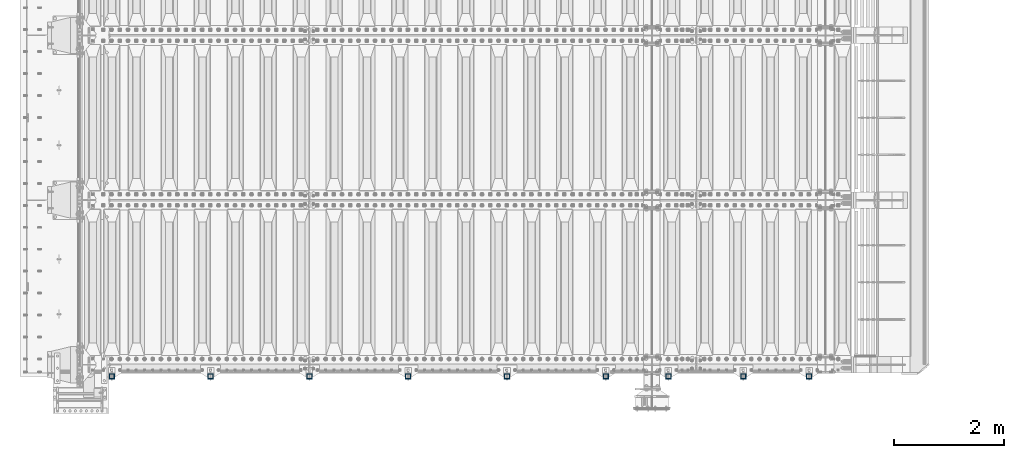
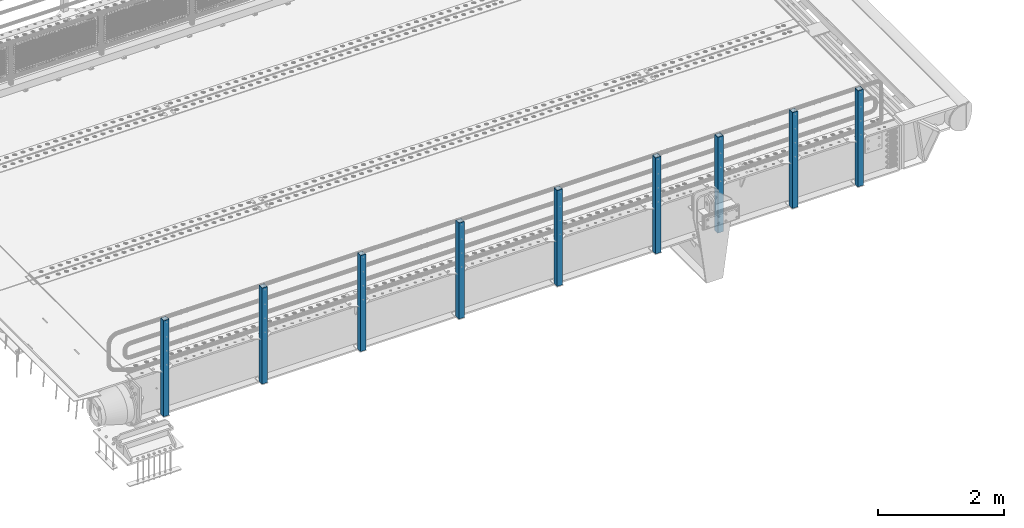
# One storey, part 59 of 219: 9 columns.
"""IFC2X3 building model written with IfcOpenShell, lengths in millimetres."""

import ifcopenshell
import ifcopenshell.guid

model = None  # the IFC model being written
_history = None  # IfcOwnerHistory: only IFC2X3 demands one
_inside = {}  # id of a spatial element -> (the spatial element, [elements in it])
_under = {}  # id of a project, library or spatial element -> (it, [spatial elements below it])
_declared = {}  # id of a project -> (the project, [libraries it declares])
_typed = {}  # id of a type object -> (the type object, [elements of that type])
_made_of = {}  # id of a material, layer set ... -> (it, [elements and type objects made of it])


def new_model(schema):
    """Start an empty IFC model of exactly this schema.

    Asked for "IFC4X3", IfcOpenShell would pick the latest addendum, in which some entities
    have other attributes; the version numbers below select the first issue.
    IFC2X3 requires an IfcOwnerHistory on every rooted entity: one is made here for all.
    """
    global model, _history
    if schema == "IFC4X3":
        model = ifcopenshell.file(schema_version=(4, 3, 0, 0))
    else:
        model = ifcopenshell.file(schema=schema)
    _inside.clear()
    _under.clear()
    _declared.clear()
    _typed.clear()
    _made_of.clear()
    _history = None
    if model.schema == "IFC2X3":
        org = make("IfcOrganization", Name="unknown")
        user = make(
            "IfcPersonAndOrganization",
            ThePerson=make("IfcPerson", FamilyName="unknown"),
            TheOrganization=org,
        )
        app = make(
            "IfcApplication",
            ApplicationDeveloper=org,
            Version="unknown",
            ApplicationFullName="unknown",
            ApplicationIdentifier="unknown",
        )
        _history = make(
            "IfcOwnerHistory",
            OwningUser=user,
            OwningApplication=app,
            ChangeAction="ADDED",
            CreationDate=0,
        )
    return model


def make(cls, **values):
    """One entity of the class cls with the attributes given. An attribute that is None is left unset."""
    return model.create_entity(
        cls, **{name: value for name, value in values.items() if value is not None}
    )


def rooted(cls, **values):
    """An entity with a GlobalId (a new one), such as an element, a storey or a relation."""
    return make(cls, GlobalId=ifcopenshell.guid.new(), OwnerHistory=_history, **values)


def si_unit(unit_type, name, prefix=None):
    """IfcSIUnit, for example si_unit("LENGTHUNIT", "METRE", prefix="MILLI")."""
    return make("IfcSIUnit", UnitType=unit_type, Prefix=prefix, Name=name)


def assignment(units):
    """IfcUnitAssignment: the units of a project."""
    return None if units is None else make("IfcUnitAssignment", Units=units)


def point(xyz):
    """IfcCartesianPoint."""
    return None if xyz is None else make("IfcCartesianPoint", Coordinates=xyz)


def direction(xyz):
    """IfcDirection."""
    return None if xyz is None else make("IfcDirection", DirectionRatios=xyz)


def frame(location, z_axis=None, x_axis=None):
    """IfcAxis2Placement3D, a coordinate frame: its origin and axes. An axis left out is left unset."""
    return make(
        "IfcAxis2Placement3D",
        Location=point(location),
        Axis=direction(z_axis),
        RefDirection=direction(x_axis),
    )


def origin_with_axes():
    """The frame at (0, 0, 0) with the z axis (0, 0, 1) and the x axis (1, 0, 0) written out."""
    return frame((0.0, 0.0, 0.0), z_axis=(0.0, 0.0, 1.0), x_axis=(1.0, 0.0, 0.0))


def place(relative_to, where):
    """IfcLocalPlacement: puts the frame where relative to a parent placement (None: the world)."""
    return make(
        "IfcLocalPlacement", PlacementRelTo=relative_to, RelativePlacement=where
    )


def context(
    kind, dimensions, precision=None, world=None, true_north=None, identifier=None
):
    """IfcGeometricRepresentationContext, for example the 3D "Model" context."""
    return make(
        "IfcGeometricRepresentationContext",
        ContextIdentifier=identifier,
        ContextType=kind,
        CoordinateSpaceDimension=dimensions,
        Precision=precision,
        WorldCoordinateSystem=world,
        TrueNorth=true_north,
    )


def subcontext(parent, identifier, kind, view, scale=None):
    """IfcGeometricRepresentationSubContext, for example "Body" below "Model"."""
    return make(
        "IfcGeometricRepresentationSubContext",
        ContextIdentifier=identifier,
        ContextType=kind,
        ParentContext=parent,
        TargetScale=scale,
        TargetView=view,
    )


def project(units=None, contexts=None):
    """IfcProject with its units and contexts."""
    return rooted(
        "IfcProject",
        Name="project",
        RepresentationContexts=contexts,
        UnitsInContext=assignment(units),
    )


def spatial(cls, under=None, at=None, **own):
    """A site, building, storey or space (cls), placed at a placement, below another one or the project."""
    s = rooted(cls, ObjectPlacement=at, **own)
    if under is not None:
        _under.setdefault(under.id(), (under, []))[1].append(s)
    return s


def faces_of(points, faces, orient=None, outer=None):
    """IfcFace entities. A face is a list of loops; a loop is a list of indices into points, from 0.

    orient and outer hold one flag for each loop. By default every Orientation is true, the
    first loop of a face is its IfcFaceOuterBound and the others are IfcFaceBound.
    """
    made = []
    for i, loops in enumerate(faces):
        bounds = []
        for j, loop in enumerate(loops):
            is_outer = j == 0 if outer is None else outer[i][j]
            bounds.append(
                make(
                    "IfcFaceOuterBound" if is_outer else "IfcFaceBound",
                    Bound=make("IfcPolyLoop", Polygon=[points[k] for k in loop]),
                    Orientation=True if orient is None else orient[i][j],
                )
            )
        made.append(make("IfcFace", Bounds=bounds))
    return made


def faceted_brep(points, faces, orient=None, outer=None, voids=None):
    """IfcFacetedBrep: a solid bounded by flat faces; with voids (closed shells), ...WithVoids."""
    shared = [point(p) for p in points]
    hull = make("IfcClosedShell", CfsFaces=faces_of(shared, faces, orient, outer))
    if voids is None:
        return make("IfcFacetedBrep", Outer=hull)
    return make(
        "IfcFacetedBrepWithVoids",
        Outer=hull,
        Voids=[
            make(cls, CfsFaces=faces_of(shared, fs, o, b)) for cls, fs, o, b in voids
        ],
    )


def shape(context_of_items, identifier, shape_type, items):
    """IfcShapeRepresentation: the items that make up one representation, for example the "Body"."""
    return make(
        "IfcShapeRepresentation",
        ContextOfItems=context_of_items,
        RepresentationIdentifier=identifier,
        RepresentationType=shape_type,
        Items=items,
    )


def material(Name=None, Category=None):
    """IfcMaterial."""
    return make("IfcMaterial", Name=Name, Category=Category)


def made_of(thing, what):
    """Note that an element or type object is made of a material, layer set ...; save() writes the relation."""
    if what is not None:
        _made_of.setdefault(what.id(), (what, []))[1].append(thing)
    return thing


def type_object(cls, material=None, **own):
    """A type object (cls), such as IfcWallType, which elements share."""
    return made_of(rooted(cls, **own), material)


def element(
    cls,
    number,
    at=None,
    inside=None,
    cuts=None,
    type_object=None,
    material=None,
    context=None,
    identifier="Body",
    shape_type=None,
    held_by="IfcProductDefinitionShape",
    body=None,
    shapes=None,
    **own,
):
    """One element of the class cls, such as IfcWall. Its Tag is "e" and its number.

    at: its placement. inside: the storey or other place that contains it. cuts: it is an
    opening in that element (IfcRelVoidsElement). A single representation is given by context,
    identifier, shape_type and body (its items); several are given by shapes. held_by: the class
    of the entity that holds the representations. save() writes the other relations.
    """
    e = rooted(cls, Tag="e%d" % number, ObjectPlacement=at, **own)
    if body is not None:
        shapes = [shape(context, identifier, shape_type, body)]
    if shapes is not None:
        e.Representation = make(held_by, Representations=shapes)
    if inside is not None:
        _inside.setdefault(inside.id(), (inside, []))[1].append(e)
    if cuts is not None:
        rooted(
            "IfcRelVoidsElement", RelatingBuildingElement=cuts, RelatedOpeningElement=e
        )
    if type_object is not None:
        _typed.setdefault(type_object.id(), (type_object, []))[1].append(e)
    return made_of(e, material)


def aggregate(whole, parts):
    """IfcRelAggregates: a whole, such as a stair, and the parts it consists of."""
    return rooted("IfcRelAggregates", RelatingObject=whole, RelatedObjects=parts)


def save(model, path):
    """Write the relations noted so far, then the file.

    IfcRelAggregates (storeys below a building ...), IfcRelContainedInSpatialStructure (elements
    in a storey), IfcRelDefinesByType, IfcRelAssociatesMaterial and IfcRelDeclares: one each for
    every whole, place, type object, material and project.
    """
    for whole, parts in _under.values():
        aggregate(whole, parts)
    for where, things in _inside.values():
        rooted(
            "IfcRelContainedInSpatialStructure",
            RelatedElements=things,
            RelatingStructure=where,
        )
    for kind, things in _typed.values():
        rooted("IfcRelDefinesByType", RelatedObjects=things, RelatingType=kind)
    for what, things in _made_of.values():
        rooted("IfcRelAssociatesMaterial", RelatedObjects=things, RelatingMaterial=what)
    for by, libraries in _declared.values():
        rooted("IfcRelDeclares", RelatingContext=by, RelatedDefinitions=libraries)
    model.write(path)


model = new_model("IFC2X3")

# Units and contexts
model_context = context("Model", 3, precision=1e-05, world=origin_with_axes())
body_context = subcontext(model_context, "Body", "Model", "MODEL_VIEW")
ifc_project = project(units=[si_unit("LENGTHUNIT", "METRE", prefix="MILLI"), si_unit("AREAUNIT", "SQUARE_METRE"), si_unit("VOLUMEUNIT", "CUBIC_METRE"), si_unit("MASSUNIT", "GRAM", prefix="KILO"), si_unit("TIMEUNIT", "SECOND"), si_unit("PLANEANGLEUNIT", "RADIAN"), si_unit("SOLIDANGLEUNIT", "STERADIAN"), si_unit("THERMODYNAMICTEMPERATUREUNIT", "DEGREE_CELSIUS"), si_unit("LUMINOUSINTENSITYUNIT", "LUMEN")], contexts=[model_context])

# Site, building, storey
site_placement = place(None, origin_with_axes())
site = spatial("IfcSite", under=ifc_project, at=site_placement, CompositionType="ELEMENT")
building_placement = place(site_placement, origin_with_axes())
building = spatial("IfcBuilding", under=site, at=building_placement, Name="Standard", CompositionType="ELEMENT")
storey_placement = place(building_placement, origin_with_axes())
storey = spatial("IfcBuildingStorey", under=building, at=storey_placement, Name="Undefined", CompositionType="ELEMENT", Elevation=0.0)

# Columns
ifc_material = material()
column_type = type_object("IfcColumnType", PredefinedType="NOTDEFINED")
for number, where, z_axis, x_axis in (
    (1, (13254.9999999999, 23789.9999999998, -844.999999999998), (0.0, 1.0, 0.0), (0.0, 0.0, 1.0)),
    (2, (12054.9999999999, 23789.9999999998, -844.999999999998), (0.0, 1.0, 0.0), (0.0, 0.0, 1.0)),
    (3, (10689.9999999999, 23789.9999999998, -844.999999999998), (0.0, 1.0, 0.0), (0.0, 0.0, 1.0)),
    (4, (9549.99999999987, 23789.9999999998, -844.999999999998), (0.0, 1.0, 0.0), (0.0, 0.0, 1.0)),
    (5, (7749.99999999987, 23789.9999999998, -844.999999999998), (0.0, 1.0, 0.0), (0.0, 0.0, 1.0)),
    (6, (5949.99999999987, 23789.9999999998, -844.999999999998), (0.0, 1.0, 0.0), (0.0, 0.0, 1.0)),
    (7, (4149.99999999987, 23789.9999999998, -844.999999999998), (0.0, 1.0, 0.0), (0.0, 0.0, 1.0)),
    (8, (2349.99999999987, 23789.9999999998, -844.999999999998), (0.0, 1.0, 0.0), (0.0, 0.0, 1.0)),
    (9, (549.999999999869, 23789.9999999998, -844.999999999998), (0.0, 1.0, 0.0), (0.0, 0.0, 1.0)),
):
    element("IfcColumn", number, at=place(storey_placement, frame(where, z_axis=z_axis, x_axis=x_axis)), inside=storey, type_object=column_type, material=ifc_material, context=body_context, shape_type="Brep", body=[
        faceted_brep([(0.0, 40.0, -40.0), (0.0, -40.0, -40.0), (1855.0, -40.0, -40.0), (1855.0, 40.0, -40.0), (0.0, -40.0, 40.0), (1855.0, -40.0, 40.0), (0.0, 40.0, 40.0), (1855.0, 40.0, 40.0), (0.0, 50.0, -50.0), (0.0, 50.0, 50.0), (1855.0, 50.0, 50.0), (1855.0, 50.0, -50.0), (0.0, -50.0, 50.0), (1855.0, -50.0, 50.0), (0.0, -50.0, -50.0), (1855.0, -50.0, -50.0)], [[[0, 1, 2, 3]], [[1, 4, 5, 2]], [[4, 6, 7, 5]], [[6, 0, 3, 7]], [[8, 9, 10, 11]], [[9, 12, 13, 10]], [[12, 14, 15, 13]], [[14, 8, 11, 15]], [[13, 15, 11, 10], [5, 7, 3, 2]], [[14, 12, 9, 8], [6, 4, 1, 0]]]),
    ])

save(model, "model.ifc")
